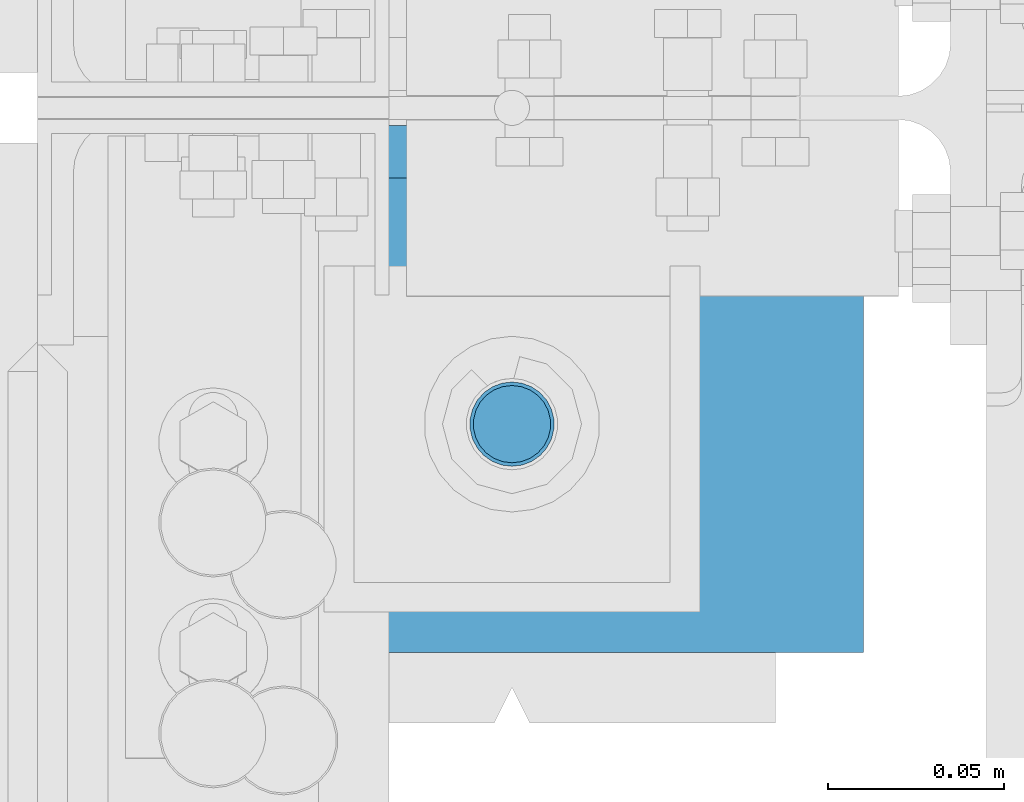
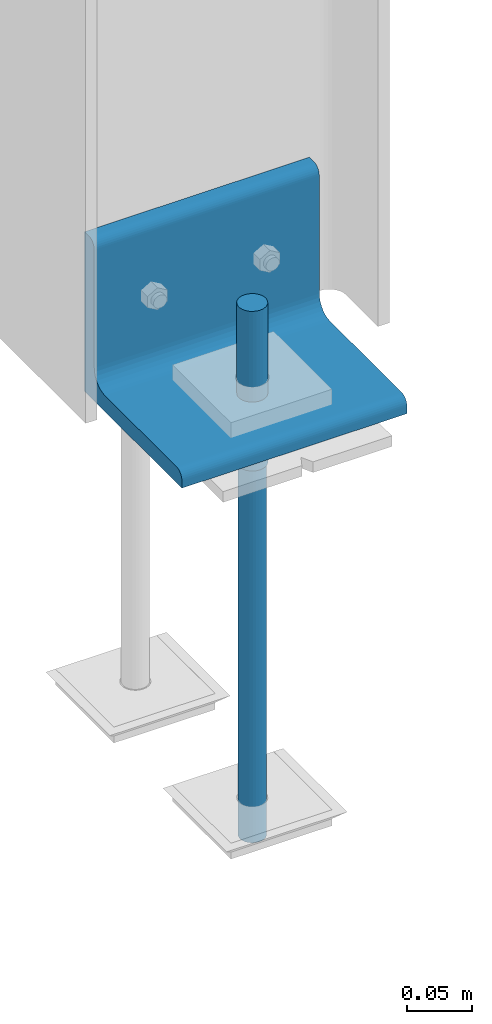
# One storey, part 75 of 496: 3 beams, 2 elements without a shape of their own.
"""IFC2X3 building model written with IfcOpenShell, lengths in millimetres."""

from ifc_helpers import new_model, si_unit, frame, origin_with_axes, origin_2d_with_axis, place, context, subcontext, project, spatial, circle, l_section, extrude, material, type_object, element, aggregate, save


model = new_model("IFC2X3")

# Units and contexts
model_context = context("Model", 3, precision=1e-05, world=origin_with_axes())
body_context = subcontext(model_context, "Body", "Model", "MODEL_VIEW")
ifc_project = project(units=[si_unit("LENGTHUNIT", "METRE", prefix="MILLI"), si_unit("AREAUNIT", "SQUARE_METRE"), si_unit("VOLUMEUNIT", "CUBIC_METRE"), si_unit("MASSUNIT", "GRAM", prefix="KILO"), si_unit("TIMEUNIT", "SECOND"), si_unit("PLANEANGLEUNIT", "RADIAN"), si_unit("SOLIDANGLEUNIT", "STERADIAN"), si_unit("THERMODYNAMICTEMPERATUREUNIT", "DEGREE_CELSIUS"), si_unit("LUMINOUSINTENSITYUNIT", "LUMEN")], contexts=[model_context])

# Site, building, storey
site_placement = place(None, origin_with_axes())
site = spatial("IfcSite", under=ifc_project, at=site_placement, CompositionType="ELEMENT")
building_placement = place(site_placement, origin_with_axes())
building = spatial("IfcBuilding", under=site, at=building_placement, Name="Undefined", CompositionType="ELEMENT")
storey_placement = place(building_placement, origin_with_axes())
storey = spatial("IfcBuildingStorey", under=building, at=storey_placement, Name="Undefined", CompositionType="ELEMENT", Elevation=0.0)

# Assembly, beams
assembly_1_placement = place(storey_placement, origin_with_axes())
assembly_1 = element("IfcElementAssembly", 1, at=assembly_1_placement, inside=storey, Name="PS24", AssemblyPlace="NOTDEFINED", PredefinedType="NOTDEFINED")
ifc_material = material(Name="Undefined/S235-E24")
beam_type_1 = type_object("IfcBeamType", Name="D24", PredefinedType="NOTDEFINED")
beam_1_placement = place(assembly_1_placement, frame((-45.0, 11309.9971504447, -100.0), z_axis=(-1.0, 0.0, 0.0), x_axis=(0.0, 0.0, -1.0)))
beam_1 = element("IfcBeam", 2, at=beam_1_placement, type_object=beam_type_1, material=ifc_material, ObjectType="D24", context=body_context, shape_type="SweptSolid", body=[
    extrude(circle(Radius=12.0, at=origin_2d_with_axis()), frame((149.999995982835, 4.54747350886464e-12, 3.63797880709171e-12), z_axis=(-1.0, 0.0, 0.0), x_axis=(0.0, -1.0, 0.0)), (0.0, 0.0, 1.0), 150.0),
])
beam_type_2 = type_object("IfcBeamType", Name="D22", PredefinedType="NOTDEFINED")
beam_2_placement = place(assembly_1_placement, frame((-45.0, 11309.9971504447, -250.0), z_axis=(-1.0, 0.0, 0.0), x_axis=(0.0, 0.0, -1.0)))
beam_2 = element("IfcBeam", 3, at=beam_2_placement, type_object=beam_type_2, material=ifc_material, ObjectType="D22", context=body_context, shape_type="SweptSolid", body=[
    extrude(circle(Radius=11.0, at=origin_2d_with_axis()), frame((350.0, 0.0, 0.0), z_axis=(-1.0, 0.0, 0.0), x_axis=(0.0, -1.0, 0.0)), (0.0, 0.0, 1.0), 350.0),
])
aggregate(assembly_1, [beam_1, beam_2])

# Assembly, beam
assembly_2_placement = place(storey_placement, origin_with_axes())
assembly_2 = element("IfcElementAssembly", 4, at=assembly_2_placement, inside=storey, AssemblyPlace="NOTDEFINED", PredefinedType="NOTDEFINED")
beam_type_3 = type_object("IfcBeamType", PredefinedType="NOTDEFINED")
beam_3_placement = place(assembly_2_placement, frame((-145.0, 11320.0, -125.0), z_axis=(0.0, 0.0, 1.0), x_axis=(1.0, 0.0, 0.0)))
beam_3 = element("IfcBeam", 5, at=beam_3_placement, type_object=beam_type_3, material=ifc_material, context=body_context, shape_type="SweptSolid", body=[
    extrude(l_section(Depth=150.0, Width=150.0, Thickness=15.0, FilletRadius=16.0, EdgeRadius=8.0, at=origin_2d_with_axis()), frame((200.0, 0.0, 0.0), z_axis=(-1.0, 0.0, 0.0), x_axis=(0.0, -1.0, 0.0)), (0.0, 0.0, 1.0), 200.0),
])
aggregate(assembly_2, [beam_3])

save(model, "model.ifc")
